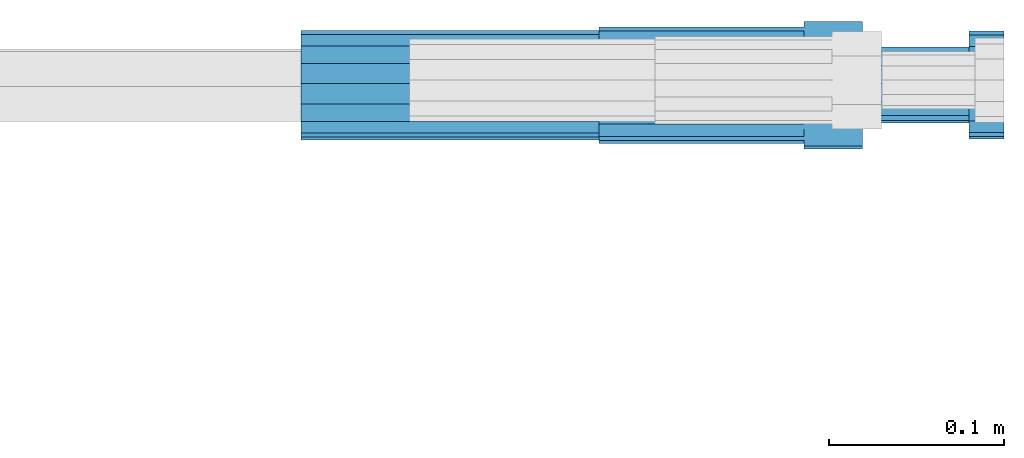
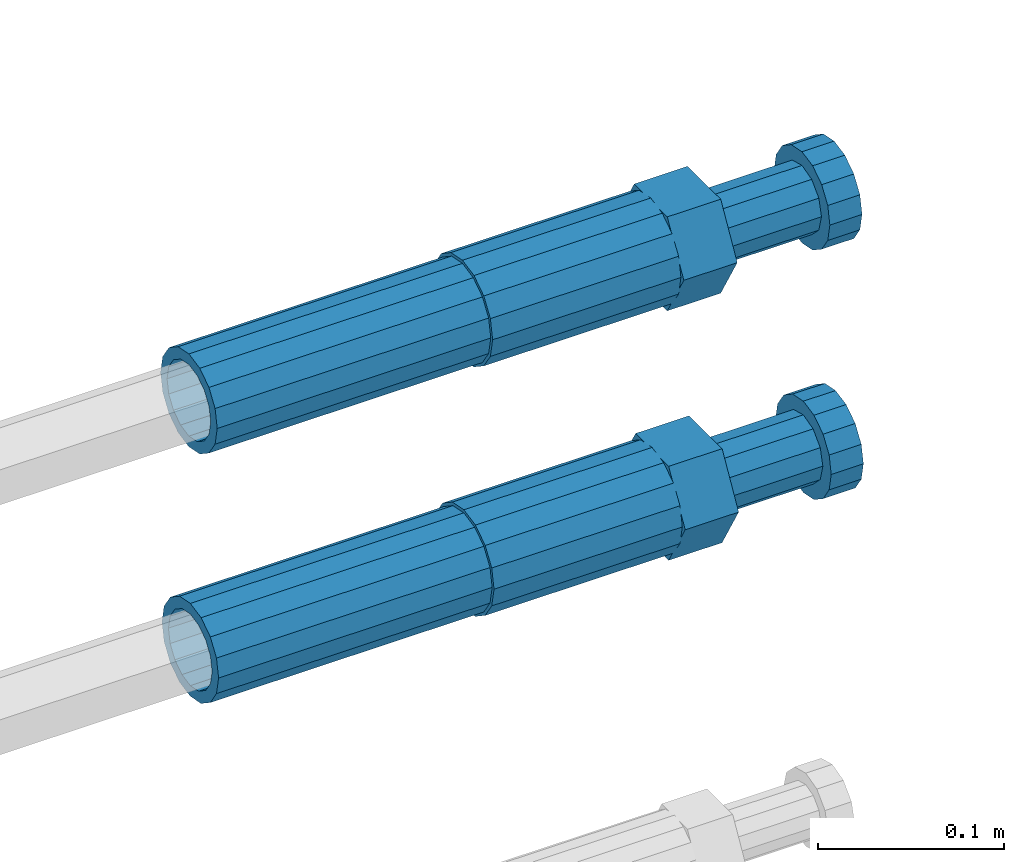
# One storey, part 111 of 119: 4 beams.
"""IFC2X3 building model written with IfcOpenShell, lengths in millimetres."""

from ifc_helpers import new_model, si_unit, frame, origin_with_axes, place, context, subcontext, project, spatial, faceted_brep, material, type_object, element, save


model = new_model("IFC2X3")

# Units and contexts
model_context = context("Model", 3, precision=1e-05, world=origin_with_axes())
body_context = subcontext(model_context, "Body", "Model", "MODEL_VIEW")
ifc_project = project(units=[si_unit("LENGTHUNIT", "METRE", prefix="MILLI"), si_unit("AREAUNIT", "SQUARE_METRE"), si_unit("VOLUMEUNIT", "CUBIC_METRE"), si_unit("MASSUNIT", "GRAM", prefix="KILO"), si_unit("TIMEUNIT", "SECOND"), si_unit("PLANEANGLEUNIT", "RADIAN"), si_unit("SOLIDANGLEUNIT", "STERADIAN"), si_unit("THERMODYNAMICTEMPERATUREUNIT", "DEGREE_CELSIUS"), si_unit("LUMINOUSINTENSITYUNIT", "LUMEN")], contexts=[model_context])

# Site, building, storey
site_placement = place(None, origin_with_axes())
site = spatial("IfcSite", under=ifc_project, at=site_placement, CompositionType="ELEMENT")
building_placement = place(site_placement, origin_with_axes())
building = spatial("IfcBuilding", under=site, at=building_placement, Name="Undefined", CompositionType="ELEMENT")
storey_placement = place(building_placement, origin_with_axes())
storey = spatial("IfcBuildingStorey", under=building, at=storey_placement, Name="Undefined", CompositionType="ELEMENT", Elevation=0.0)

# Beams
ifc_material = material(Name="STEEL/S275")
beam_type_1 = type_object("IfcBeamType", PredefinedType="NOTDEFINED")
beam_1_placement = place(storey_placement, frame((2039349.04023304, 6206399.98994599, 19251.9794145845), z_axis=(0.0, 0.0, 1.0), x_axis=(1.0, 0.0, 0.0)))
element("IfcBeam", 1, at=beam_1_placement, inside=storey, type_object=beam_type_1, material=ifc_material, Name="AG40N", context=body_context, shape_type="Brep", body=[
    faceted_brep([(1.62981450557709e-09, -23.4999999990687, 0.0), (7.45058059692383e-09, -21.7111690142192, 8.99306066057534), (170.000002125278, -21.711168999318, 8.99306066022245), (170.000002127141, -23.4999999844003, -3.66071617463604e-10), (4.65661287307739e-09, -16.6170093587134, 16.6170093578889), (170.000002122484, -16.6170093440451, 16.6170093575288), (1.86264514923096e-09, -8.99306066217832, 21.7111690140277), (170.000002118759, -8.99306064750999, 21.7111690136603), (2.3283064365387e-10, 9.31322574615479e-10, 23.5), (170.000002114102, 1.28056854009628e-08, 23.4999999996485), (-6.51925802230835e-09, 8.99306065868586, 21.7111690140241), (170.00000211224, 8.99306067335419, 21.7111690136639), (-7.45058059692383e-09, 16.6170093561523, 16.6170093578853), (170.000002109446, 16.6170093708206, 16.6170093575324), (-9.31322574615479e-09, 21.711169013055, 8.99306066057534), (170.000002108514, 21.7111690277234, 8.99306066022245), (-1.16415321826935e-09, 23.5000000009313, 0.0), (170.000002108514, 23.5000000144355, -3.66071617463604e-10), (-8.38190317153931e-09, 21.7111690151505, -8.99306066059444), (170.000002110377, 21.7111690300517, -8.9930606609546), (-5.58793544769287e-09, 16.6170093598776, -16.6170093579008), (170.000002113171, 16.6170093745459, -16.6170093582609), (-9.31322574615479e-10, 8.99306066334248, -21.7111690140396), (170.000002115965, 8.99306067801081, -21.7111690143961), (2.3283064365387e-10, 9.31322574615479e-10, -23.5), (170.00000211969, 1.7927959561348e-08, -23.5000000003843), (5.58793544769287e-09, -8.99306065752171, -21.7111690140396), (170.000002123415, -8.99306064285338, -21.7111690143961), (8.38190317153931e-09, -16.6170093549881, -16.6170093579008), (170.000002125278, -16.6170093403198, -16.6170093582646), (9.31322574615479e-09, -21.7111690121237, -8.99306066059444), (170.000002127141, -21.7111689972226, -8.9930606609546), (1.11758708953857e-08, -30.4999999990687, -9.54969436861575e-12), (1.30385160446167e-08, -28.1783257392235, -11.6718446871514), (170.000002129003, -28.1783257243223, -11.6718446875116), (170.000002129935, -30.4999999841675, -3.66071617463604e-10), (1.02445483207703e-08, -21.5667568228673, -21.5667568262129), (170.000002128072, -21.566756808199, -21.5667568265694), (7.45058059692383e-09, -11.6718446831219, -28.1783257416196), (170.000002125278, -11.6718446684536, -28.1783257419834), (3.72529029846191e-09, 3.95812094211578e-09, -30.5000000000277), (170.00000211969, 1.83936208486557e-08, -30.5000000003879), (-9.31322574615479e-10, 11.6718446905725, -28.1783257416232), (170.000002115965, 11.6718447052408, -28.1783257419797), (-6.51925802230835e-09, 21.5667568286881, -21.5667568262093), (170.000002110377, 21.5667568433564, -21.5667568265694), (-9.31322574615479e-09, 28.178325742716, -11.6718446871478), (170.000002108514, 28.1783257573843, -11.6718446875079), (-1.21071934700012e-08, 30.5, -5.91171556152403e-12), (170.000002106652, 30.5000000144355, -3.62433638656512e-10), (-1.21071934700012e-08, 28.1783257401548, 11.6718446871359), (170.00000210572, 28.1783257548232, 11.6718446867794), (-1.02445483207703e-08, 21.5667568240315, 21.5667568261974), (170.000002107583, 21.566756838467, 21.5667568258409), (-7.45058059692383e-09, 11.671844684286, 28.1783257416041), (170.000002110377, 11.6718446989544, 28.178325741244), (-2.79396772384644e-09, -2.56113708019257e-09, 30.5000000000159), (170.000002114102, 1.18743628263474e-08, 30.4999999996558), (1.86264514923096e-09, -11.6718446896411, 28.1783257416114), (170.000002118759, -11.67184467474, 28.178325741244), (7.45058059692383e-09, -21.5667568275239, 21.5667568261974), (170.000002123415, -21.5667568126228, 21.5667568258373), (1.02445483207703e-08, -28.1783257415518, 11.6718446871359), (170.000002127141, -28.1783257271163, 11.6718446867794)], [[[0, 1, 2, 3]], [[1, 4, 5, 2]], [[4, 6, 7, 5]], [[6, 8, 9, 7]], [[8, 10, 11, 9]], [[10, 12, 13, 11]], [[12, 14, 15, 13]], [[14, 16, 17, 15]], [[16, 18, 19, 17]], [[18, 20, 21, 19]], [[20, 22, 23, 21]], [[22, 24, 25, 23]], [[24, 26, 27, 25]], [[26, 28, 29, 27]], [[28, 30, 31, 29]], [[30, 0, 3, 31]], [[32, 33, 34, 35]], [[33, 36, 37, 34]], [[36, 38, 39, 37]], [[38, 40, 41, 39]], [[40, 42, 43, 41]], [[42, 44, 45, 43]], [[44, 46, 47, 45]], [[46, 48, 49, 47]], [[48, 50, 51, 49]], [[50, 52, 53, 51]], [[52, 54, 55, 53]], [[54, 56, 57, 55]], [[56, 58, 59, 57]], [[58, 60, 61, 59]], [[60, 62, 63, 61]], [[62, 32, 35, 63]], [[37, 39, 41, 43, 45, 47, 49, 51, 53, 55, 57, 59, 61, 63, 35, 34], [5, 7, 9, 11, 13, 15, 17, 19, 21, 23, 25, 27, 29, 31, 3, 2]], [[62, 60, 58, 56, 54, 52, 50, 48, 46, 44, 42, 40, 38, 36, 33, 32], [30, 28, 26, 24, 22, 20, 18, 16, 14, 12, 10, 8, 6, 4, 1, 0]]]),
])
beam_2_placement = place(storey_placement, frame((2039349.04023304, 6206401.47994599, 19414.989415702), z_axis=(0.0, 0.0, 1.0), x_axis=(1.0, 0.0, 0.0)))
element("IfcBeam", 2, at=beam_2_placement, inside=storey, type_object=beam_type_1, material=ifc_material, Name="AG40N", context=body_context, shape_type="Brep", body=[
    faceted_brep([(1.62981450557709e-09, -23.4999999990687, 0.0), (7.45058059692383e-09, -21.7111690142192, 8.99306066057534), (170.000002125278, -21.711168999318, 8.99306066022245), (170.000002127141, -23.4999999844003, -3.66071617463604e-10), (4.65661287307739e-09, -16.6170093587134, 16.6170093578889), (170.000002122484, -16.6170093440451, 16.6170093575288), (1.86264514923096e-09, -8.99306066217832, 21.7111690140277), (170.000002118759, -8.99306064750999, 21.7111690136603), (2.3283064365387e-10, 9.31322574615479e-10, 23.5), (170.000002114102, 1.28056854009628e-08, 23.4999999996485), (-6.51925802230835e-09, 8.99306065868586, 21.7111690140241), (170.00000211224, 8.99306067335419, 21.7111690136639), (-7.45058059692383e-09, 16.6170093561523, 16.6170093578853), (170.000002109446, 16.6170093708206, 16.6170093575324), (-9.31322574615479e-09, 21.711169013055, 8.99306066057534), (170.000002108514, 21.7111690277234, 8.99306066022245), (-1.16415321826935e-09, 23.5000000009313, 0.0), (170.000002108514, 23.5000000144355, -3.66071617463604e-10), (-8.38190317153931e-09, 21.7111690151505, -8.99306066059444), (170.000002110377, 21.7111690300517, -8.9930606609546), (-5.58793544769287e-09, 16.6170093598776, -16.6170093579008), (170.000002113171, 16.6170093745459, -16.6170093582609), (-9.31322574615479e-10, 8.99306066334248, -21.7111690140396), (170.000002115965, 8.99306067801081, -21.7111690143961), (2.3283064365387e-10, 9.31322574615479e-10, -23.5), (170.00000211969, 1.7927959561348e-08, -23.5000000003843), (5.58793544769287e-09, -8.99306065752171, -21.7111690140396), (170.000002123415, -8.99306064285338, -21.7111690143961), (8.38190317153931e-09, -16.6170093549881, -16.6170093579008), (170.000002125278, -16.6170093403198, -16.6170093582646), (9.31322574615479e-09, -21.7111690121237, -8.99306066059444), (170.000002127141, -21.7111689972226, -8.9930606609546), (1.11758708953857e-08, -30.4999999990687, -9.54969436861575e-12), (1.30385160446167e-08, -28.1783257392235, -11.6718446871514), (170.000002129003, -28.1783257243223, -11.6718446875116), (170.000002129935, -30.4999999841675, -3.66071617463604e-10), (1.02445483207703e-08, -21.5667568228673, -21.5667568262129), (170.000002128072, -21.566756808199, -21.5667568265694), (7.45058059692383e-09, -11.6718446831219, -28.1783257416196), (170.000002125278, -11.6718446684536, -28.1783257419834), (3.72529029846191e-09, 3.95812094211578e-09, -30.5000000000277), (170.00000211969, 1.83936208486557e-08, -30.5000000003879), (-9.31322574615479e-10, 11.6718446905725, -28.1783257416232), (170.000002115965, 11.6718447052408, -28.1783257419797), (-6.51925802230835e-09, 21.5667568286881, -21.5667568262093), (170.000002110377, 21.5667568433564, -21.5667568265694), (-9.31322574615479e-09, 28.178325742716, -11.6718446871478), (170.000002108514, 28.1783257573843, -11.6718446875079), (-1.21071934700012e-08, 30.5, -5.91171556152403e-12), (170.000002106652, 30.5000000144355, -3.62433638656512e-10), (-1.21071934700012e-08, 28.1783257401548, 11.6718446871359), (170.00000210572, 28.1783257548232, 11.6718446867794), (-1.02445483207703e-08, 21.5667568240315, 21.5667568261974), (170.000002107583, 21.566756838467, 21.5667568258409), (-7.45058059692383e-09, 11.671844684286, 28.1783257416041), (170.000002110377, 11.6718446989544, 28.178325741244), (-2.79396772384644e-09, -2.56113708019257e-09, 30.5000000000159), (170.000002114102, 1.18743628263474e-08, 30.4999999996558), (1.86264514923096e-09, -11.6718446896411, 28.1783257416114), (170.000002118759, -11.67184467474, 28.178325741244), (7.45058059692383e-09, -21.5667568275239, 21.5667568261974), (170.000002123415, -21.5667568126228, 21.5667568258373), (1.02445483207703e-08, -28.1783257415518, 11.6718446871359), (170.000002127141, -28.1783257271163, 11.6718446867794)], [[[0, 1, 2, 3]], [[1, 4, 5, 2]], [[4, 6, 7, 5]], [[6, 8, 9, 7]], [[8, 10, 11, 9]], [[10, 12, 13, 11]], [[12, 14, 15, 13]], [[14, 16, 17, 15]], [[16, 18, 19, 17]], [[18, 20, 21, 19]], [[20, 22, 23, 21]], [[22, 24, 25, 23]], [[24, 26, 27, 25]], [[26, 28, 29, 27]], [[28, 30, 31, 29]], [[30, 0, 3, 31]], [[32, 33, 34, 35]], [[33, 36, 37, 34]], [[36, 38, 39, 37]], [[38, 40, 41, 39]], [[40, 42, 43, 41]], [[42, 44, 45, 43]], [[44, 46, 47, 45]], [[46, 48, 49, 47]], [[48, 50, 51, 49]], [[50, 52, 53, 51]], [[52, 54, 55, 53]], [[54, 56, 57, 55]], [[56, 58, 59, 57]], [[58, 60, 61, 59]], [[60, 62, 63, 61]], [[62, 32, 35, 63]], [[37, 39, 41, 43, 45, 47, 49, 51, 53, 55, 57, 59, 61, 63, 35, 34], [5, 7, 9, 11, 13, 15, 17, 19, 21, 23, 25, 27, 29, 31, 3, 2]], [[62, 60, 58, 56, 54, 52, 50, 48, 46, 44, 42, 40, 38, 36, 33, 32], [30, 28, 26, 24, 22, 20, 18, 16, 14, 12, 10, 8, 6, 4, 1, 0]]]),
])
beam_type_2 = type_object("IfcBeamType", Name="ROD65", PredefinedType="NOTDEFINED")
beam_3_placement = place(storey_placement, frame((2039519.04023304, 6206399.98994599, 19251.9794170917), z_axis=(0.0, 0.0, 1.0), x_axis=(1.0, 0.0, 0.0)))
element("IfcBeam", 3, at=beam_3_placement, inside=storey, type_object=beam_type_2, material=ifc_material, Name="AGB40", ObjectType="ROD65", context=body_context, shape_type="Brep", body=[
    faceted_brep([(116.999999999069, 17.8249999252148, 30.8738056446964), (116.999999998137, 22.0056957420893, 23.632628078838), (116.999999999069, 12.4372115600854, 30.0260848066173), (116.999999999069, 8.17543111252598, 30.8738056446964), (117.000000000931, -17.8250000746921, 30.8738056446964), (150.200000001118, -17.8250000723638, 30.8738056446964), (150.199999999255, 17.8249999275431, 30.8738056446964), (117.000000000931, -8.17543109622784, 30.8738056446964), (117.000000001863, -22.0056959956419, 23.6326278985034), (117.000000000931, -12.4372115437873, 30.0260848066173), (117.000000001863, -35.6500000746455, -2.18278728425503e-10), (150.200000002049, -35.6500000723172, -2.18278728425503e-10), (117.000000001863, -30.8443149488885, 8.32369080289209), (117.000000001863, -30.8443149488885, -8.32369080355784), (117.000000002794, -32.4999999918509, 0.0), (117.000000000931, -17.8250000746921, -30.873805645133), (150.200000001118, -17.8250000723638, -30.873805645133), (117.000000001863, -22.0056959961075, -23.6326278982269), (117.000000000931, -8.17543109389953, -30.873805645133), (117.000000000931, -12.4372115437873, -30.0260848066173), (116.999999999069, 17.8249999252148, -30.873805645133), (150.199999999255, 17.8249999275431, -30.873805645133), (116.999999999069, 8.17543111019768, -30.873805645133), (116.999999999069, 12.4372115600854, -30.0260848066173), (116.999999998137, 22.005695742555, -23.6326280785652), (116.999999998137, 35.6499999251682, -2.18278728425503e-10), (150.199999998324, 35.6499999277294, -2.18278728425503e-10), (116.999999998137, 30.8443150522653, -8.32369036550881), (116.999999997206, 32.5000000081491, 0.0), (116.999999998137, 30.8443150522653, 8.32369036483942), (1.86264514923096e-09, -22.9809703885112, 22.9809703885621), (1.86264514923096e-09, -30.0260848065373, 12.4372115518672), (117.000000001863, -30.0260847983882, 12.4372115518672), (117.000000001863, -22.9809703803621, 22.9809703885621), (-1.86264514923096e-09, 22.9809703885112, -22.9809703885621), (-1.86264514923096e-09, 30.0260848065373, -12.4372115518672), (116.999999998137, 30.0260848146863, -12.4372115518672), (116.999999998137, 22.9809703966603, -22.9809703885621), (1.86264514923096e-09, -30.0260848065373, -12.4372115518672), (1.86264514923096e-09, -22.9809703885112, -22.9809703885621), (117.000000001863, -22.9809703803621, -22.9809703885621), (117.000000001863, -30.0260847983882, -12.4372115518672), (9.31322574615479e-10, -12.4372115519363, 30.0260848066173), (0.0, 0.0, 32.5), (-9.31322574615479e-10, 12.4372115519363, 30.0260848066173), (-1.86264514923096e-09, 22.9809703885112, 22.9809703885621), (-1.86264514923096e-09, 30.0260848065373, 12.4372115518672), (-2.79396772384644e-09, 32.5, 0.0), (-9.31322574615479e-10, 12.4372115519363, -30.0260848066173), (0.0, 0.0, -32.5), (9.31322574615479e-10, -12.4372115519363, -30.0260848066173), (2.79396772384644e-09, -32.5, 0.0), (116.999999998137, 22.9809703966603, 22.9809703885621), (116.999999998137, 30.0260848146863, 12.4372115518672), (117.0, 8.14907252788544e-09, -32.5), (117.0, 8.14907252788544e-09, 32.5), (150.200000000186, -10.5000000959262, 18.1865334791873), (150.199999999255, -9.59262251853943e-08, 20.9999999997126), (150.199999998324, 10.4999999040738, 18.1865334791873), (150.199999997392, 18.1865333835594, 10.4999999997126), (150.199999997392, 20.9999999040738, -2.87400325760245e-10), (150.199999997392, 18.1865333835594, -10.5000000002874), (150.199999998324, 10.4999999040738, -18.1865334797621), (150.199999999255, -9.59262251853943e-08, -21.0000000002874), (150.200000000186, -10.5000000959262, -18.1865334797621), (150.200000000186, -18.1865335754119, -10.5000000002874), (150.200000001118, -21.0000000959262, -2.87400325760245e-10), (150.200000000186, -18.1865335754119, 10.4999999997126), (210.979999999516, 10.4999999082647, 18.1865334791873), (210.979999999516, -9.17352735996246e-08, 20.9999999997126), (210.979999997653, 18.1865333877504, 10.4999999997126), (210.979999997653, 20.9999999082647, -2.87400325760245e-10), (210.979999997653, 18.1865333877504, -10.5000000002874), (210.979999999516, 10.4999999082647, -18.1865334797621), (210.979999999516, -9.17352735996246e-08, -21.0000000002874), (210.979999999516, -10.5000000917353, -18.1865334797621), (210.980000000447, -18.1865335712209, -10.5000000002874), (210.980000001378, -21.0000000917353, -2.87400325760245e-10), (210.980000000447, -18.1865335712209, 10.4999999997126), (210.979999999516, -10.5000000917353, 18.1865334791873), (211.001368402503, -27.7269939335529, -11.4911163272045), (211.003082515672, -21.2238095656503, -21.2238154190527), (231.002518340945, -21.2131946226582, -21.2132004554769), (231.000804228708, -27.7163789905608, -11.4805013636287), (211.001368415542, -11.4911086384673, -27.7269970399575), (231.000804241747, -11.4804936954752, -27.7163820763781), (210.996487061493, -0.0106066407170147, -30.0106107396168), (230.995922887698, 8.30227509140968e-06, -29.999995776041), (210.98918159306, 11.4698940692469, -27.7269970332745), (230.988617419265, 11.4805090120062, -27.7163820696951), (210.980564201251, 21.2025913291145, -21.2238154067054), (230.980000027455, 21.2132062721066, -21.2132004431296), (210.971946807578, 27.7057702087332, -11.4911163110701), (230.971382633783, 27.7163851517253, -11.4805013474943), (210.964641331695, 29.9893806746695, -0.0106149565435771), (230.9640771579, 29.9999956176616, 7.03221303410828e-09), (210.959759964608, 27.7057637346443, 11.4698863966551), (230.959195790812, 27.7163786776364, 11.4805013602345), (210.958045851439, 21.2025793667417, 21.2025854885032), (230.957481677644, 21.2131943097338, 21.2132004520827), (210.959759951569, 11.4698784395587, 27.705767109408), (230.959195776843, 11.4804933823179, 27.7163820729838), (210.964641305618, -0.0106235581915826, 29.9893808090674), (230.964077131823, -8.61519947648048e-06, 29.9999957726432), (210.971946774051, -11.4911242681555, 27.7057671027251), (230.971382599324, -11.4805093251634, 27.7163820663009), (210.98056416586, -21.2238215280231, 21.2025854761559), (230.979999991134, -21.2132065852638, 21.2132004397354), (210.989181559533, -27.7270004076418, 11.4698863805206), (230.988617384806, -27.7163854646496, 11.4805013441), (210.996487035416, -30.0106108735781, -0.0106149740058754), (230.995922861621, -29.999995930586, -1.04300852399319e-08)], [[[0, 1, 2, 3]], [[4, 5, 6, 0, 3, 7]], [[8, 4, 7, 9]], [[10, 11, 5, 4, 8, 12]], [[13, 10, 12, 14]], [[15, 16, 11, 10, 13, 17]], [[18, 15, 17, 19]], [[20, 21, 16, 15, 18, 22]], [[20, 22, 23, 24]], [[25, 26, 21, 20, 24, 27]], [[25, 27, 28, 29]], [[30, 31, 32, 33]], [[34, 35, 36, 37]], [[38, 39, 40, 41]], [[31, 30, 42, 43, 44, 45, 46, 47, 35, 34, 48, 49, 50, 39, 38, 51]], [[46, 45, 52, 53]], [[28, 47, 46, 53, 29]], [[27, 36, 35, 47, 28]], [[24, 37, 36, 27]], [[23, 48, 34, 37, 24]], [[22, 54, 49, 48, 23]], [[18, 54, 22]], [[19, 50, 49, 54, 18]], [[17, 40, 39, 50, 19]], [[13, 41, 40, 17]], [[14, 51, 38, 41, 13]], [[12, 32, 31, 51, 14]], [[8, 33, 32, 12]], [[9, 42, 30, 33, 8]], [[7, 55, 43, 42, 9]], [[3, 55, 7]], [[2, 44, 43, 55, 3]], [[1, 52, 45, 44, 2]], [[29, 53, 52, 1]], [[0, 6, 26, 25, 29, 1]], [[5, 11, 16, 21, 26, 6], [56, 57, 58, 59, 60, 61, 62, 63, 64, 65, 66, 67]], [[68, 58, 57, 69]], [[70, 59, 58, 68]], [[71, 60, 59, 70]], [[72, 61, 60, 71]], [[73, 62, 61, 72]], [[74, 63, 62, 73]], [[75, 64, 63, 74]], [[76, 65, 64, 75]], [[77, 66, 65, 76]], [[78, 67, 66, 77]], [[79, 56, 67, 78]], [[69, 57, 56, 79]], [[80, 81, 82, 83]], [[81, 84, 85, 82]], [[84, 86, 87, 85]], [[86, 88, 89, 87]], [[88, 90, 91, 89]], [[90, 92, 93, 91]], [[92, 94, 95, 93]], [[94, 96, 97, 95]], [[96, 98, 99, 97]], [[98, 100, 101, 99]], [[100, 102, 103, 101]], [[102, 104, 105, 103]], [[104, 106, 107, 105]], [[106, 108, 109, 107]], [[108, 110, 111, 109]], [[82, 85, 87, 89, 91, 93, 95, 97, 99, 101, 103, 105, 107, 109, 111, 83]], [[110, 80, 83, 111]], [[108, 106, 104, 102, 100, 98, 96, 94, 92, 90, 88, 86, 84, 81, 80, 110], [78, 77, 76, 75, 74, 73, 72, 71, 70, 68, 69, 79]]]),
])
beam_4_placement = place(storey_placement, frame((2039519.04023304, 6206401.47994599, 19414.989418229), z_axis=(0.0, 0.0, 1.0), x_axis=(1.0, 0.0, 0.0)))
element("IfcBeam", 4, at=beam_4_placement, inside=storey, type_object=beam_type_2, material=ifc_material, Name="AGB40", ObjectType="ROD65", context=body_context, shape_type="Brep", body=[
    faceted_brep([(116.999999999069, 17.8249999252148, 30.8738056446964), (116.999999998137, 22.0056957420893, 23.632628078838), (116.999999999069, 12.4372115600854, 30.0260848066173), (116.999999999069, 8.17543111252598, 30.8738056446964), (117.000000000931, -17.8250000746921, 30.8738056446964), (150.200000001118, -17.8250000723638, 30.8738056446964), (150.199999999255, 17.8249999275431, 30.8738056446964), (117.000000000931, -8.17543109622784, 30.8738056446964), (117.000000001863, -22.0056959956419, 23.6326278985034), (117.000000000931, -12.4372115437873, 30.0260848066173), (117.000000001863, -35.6500000746455, -2.18278728425503e-10), (150.200000002049, -35.6500000723172, -2.18278728425503e-10), (117.000000001863, -30.8443149488885, 8.32369080289209), (117.000000001863, -30.8443149488885, -8.32369080355784), (117.000000002794, -32.4999999918509, 0.0), (117.000000000931, -17.8250000746921, -30.873805645133), (150.200000001118, -17.8250000723638, -30.873805645133), (117.000000001863, -22.0056959961075, -23.6326278982269), (117.000000000931, -8.17543109389953, -30.873805645133), (117.000000000931, -12.4372115437873, -30.0260848066173), (116.999999999069, 17.8249999252148, -30.873805645133), (150.199999999255, 17.8249999275431, -30.873805645133), (116.999999999069, 8.17543111019768, -30.873805645133), (116.999999999069, 12.4372115600854, -30.0260848066173), (116.999999998137, 22.005695742555, -23.6326280785652), (116.999999998137, 35.6499999251682, -2.18278728425503e-10), (150.199999998324, 35.6499999277294, -2.18278728425503e-10), (116.999999998137, 30.8443150522653, -8.32369036550881), (116.999999997206, 32.5000000081491, 0.0), (116.999999998137, 30.8443150522653, 8.32369036483942), (1.86264514923096e-09, -22.9809703885112, 22.9809703885621), (1.86264514923096e-09, -30.0260848065373, 12.4372115518672), (117.000000001863, -30.0260847983882, 12.4372115518672), (117.000000001863, -22.9809703803621, 22.9809703885621), (-1.86264514923096e-09, 22.9809703885112, -22.9809703885621), (-1.86264514923096e-09, 30.0260848065373, -12.4372115518672), (116.999999998137, 30.0260848146863, -12.4372115518672), (116.999999998137, 22.9809703966603, -22.9809703885621), (1.86264514923096e-09, -30.0260848065373, -12.4372115518672), (1.86264514923096e-09, -22.9809703885112, -22.9809703885621), (117.000000001863, -22.9809703803621, -22.9809703885621), (117.000000001863, -30.0260847983882, -12.4372115518672), (9.31322574615479e-10, -12.4372115519363, 30.0260848066173), (0.0, 0.0, 32.5), (-9.31322574615479e-10, 12.4372115519363, 30.0260848066173), (-1.86264514923096e-09, 22.9809703885112, 22.9809703885621), (-1.86264514923096e-09, 30.0260848065373, 12.4372115518672), (-2.79396772384644e-09, 32.5, 0.0), (-9.31322574615479e-10, 12.4372115519363, -30.0260848066173), (0.0, 0.0, -32.5), (9.31322574615479e-10, -12.4372115519363, -30.0260848066173), (2.79396772384644e-09, -32.5, 0.0), (116.999999998137, 22.9809703966603, 22.9809703885621), (116.999999998137, 30.0260848146863, 12.4372115518672), (117.0, 8.14907252788544e-09, -32.5), (117.0, 8.14907252788544e-09, 32.5), (150.200000000186, -10.5000000959262, 18.1865334791873), (150.199999999255, -9.59262251853943e-08, 20.9999999997126), (150.199999998324, 10.4999999040738, 18.1865334791873), (150.199999997392, 18.1865333835594, 10.4999999997126), (150.199999997392, 20.9999999040738, -2.87400325760245e-10), (150.199999997392, 18.1865333835594, -10.5000000002874), (150.199999998324, 10.4999999040738, -18.1865334797621), (150.199999999255, -9.59262251853943e-08, -21.0000000002874), (150.200000000186, -10.5000000959262, -18.1865334797621), (150.200000000186, -18.1865335754119, -10.5000000002874), (150.200000001118, -21.0000000959262, -2.87400325760245e-10), (150.200000000186, -18.1865335754119, 10.4999999997126), (210.979999999516, 10.4999999082647, 18.1865334791873), (210.979999999516, -9.17352735996246e-08, 20.9999999997126), (210.979999997653, 18.1865333877504, 10.4999999997126), (210.979999997653, 20.9999999082647, -2.87400325760245e-10), (210.979999997653, 18.1865333877504, -10.5000000002874), (210.979999999516, 10.4999999082647, -18.1865334797621), (210.979999999516, -9.17352735996246e-08, -21.0000000002874), (210.979999999516, -10.5000000917353, -18.1865334797621), (210.980000000447, -18.1865335712209, -10.5000000002874), (210.980000001378, -21.0000000917353, -2.87400325760245e-10), (210.980000000447, -18.1865335712209, 10.4999999997126), (210.979999999516, -10.5000000917353, 18.1865334791873), (211.001368402503, -27.7269939335529, -11.4911163272045), (211.003082515672, -21.2238095656503, -21.2238154190527), (231.002518340945, -21.2131946226582, -21.2132004554769), (231.000804228708, -27.7163789905608, -11.4805013636287), (211.001368415542, -11.4911086384673, -27.7269970399575), (231.000804241747, -11.4804936954752, -27.7163820763781), (210.996487061493, -0.0106066407170147, -30.0106107396168), (230.995922887698, 8.30227509140968e-06, -29.999995776041), (210.98918159306, 11.4698940692469, -27.7269970332745), (230.988617419265, 11.4805090120062, -27.7163820696951), (210.980564201251, 21.2025913291145, -21.2238154067054), (230.980000027455, 21.2132062721066, -21.2132004431296), (210.971946807578, 27.7057702087332, -11.4911163110701), (230.971382633783, 27.7163851517253, -11.4805013474943), (210.964641331695, 29.9893806746695, -0.0106149565435771), (230.9640771579, 29.9999956176616, 7.03221303410828e-09), (210.959759964608, 27.7057637346443, 11.4698863966551), (230.959195790812, 27.7163786776364, 11.4805013602345), (210.958045851439, 21.2025793667417, 21.2025854885032), (230.957481677644, 21.2131943097338, 21.2132004520827), (210.959759951569, 11.4698784395587, 27.705767109408), (230.959195776843, 11.4804933823179, 27.7163820729838), (210.964641305618, -0.0106235581915826, 29.9893808090674), (230.964077131823, -8.61519947648048e-06, 29.9999957726432), (210.971946774051, -11.4911242681555, 27.7057671027251), (230.971382599324, -11.4805093251634, 27.7163820663009), (210.98056416586, -21.2238215280231, 21.2025854761559), (230.979999991134, -21.2132065852638, 21.2132004397354), (210.989181559533, -27.7270004076418, 11.4698863805206), (230.988617384806, -27.7163854646496, 11.4805013441), (210.996487035416, -30.0106108735781, -0.0106149740058754), (230.995922861621, -29.999995930586, -1.04300852399319e-08)], [[[0, 1, 2, 3]], [[4, 5, 6, 0, 3, 7]], [[8, 4, 7, 9]], [[10, 11, 5, 4, 8, 12]], [[13, 10, 12, 14]], [[15, 16, 11, 10, 13, 17]], [[18, 15, 17, 19]], [[20, 21, 16, 15, 18, 22]], [[20, 22, 23, 24]], [[25, 26, 21, 20, 24, 27]], [[25, 27, 28, 29]], [[30, 31, 32, 33]], [[34, 35, 36, 37]], [[38, 39, 40, 41]], [[31, 30, 42, 43, 44, 45, 46, 47, 35, 34, 48, 49, 50, 39, 38, 51]], [[46, 45, 52, 53]], [[28, 47, 46, 53, 29]], [[27, 36, 35, 47, 28]], [[24, 37, 36, 27]], [[23, 48, 34, 37, 24]], [[22, 54, 49, 48, 23]], [[18, 54, 22]], [[19, 50, 49, 54, 18]], [[17, 40, 39, 50, 19]], [[13, 41, 40, 17]], [[14, 51, 38, 41, 13]], [[12, 32, 31, 51, 14]], [[8, 33, 32, 12]], [[9, 42, 30, 33, 8]], [[7, 55, 43, 42, 9]], [[3, 55, 7]], [[2, 44, 43, 55, 3]], [[1, 52, 45, 44, 2]], [[29, 53, 52, 1]], [[0, 6, 26, 25, 29, 1]], [[5, 11, 16, 21, 26, 6], [56, 57, 58, 59, 60, 61, 62, 63, 64, 65, 66, 67]], [[68, 58, 57, 69]], [[70, 59, 58, 68]], [[71, 60, 59, 70]], [[72, 61, 60, 71]], [[73, 62, 61, 72]], [[74, 63, 62, 73]], [[75, 64, 63, 74]], [[76, 65, 64, 75]], [[77, 66, 65, 76]], [[78, 67, 66, 77]], [[79, 56, 67, 78]], [[69, 57, 56, 79]], [[80, 81, 82, 83]], [[81, 84, 85, 82]], [[84, 86, 87, 85]], [[86, 88, 89, 87]], [[88, 90, 91, 89]], [[90, 92, 93, 91]], [[92, 94, 95, 93]], [[94, 96, 97, 95]], [[96, 98, 99, 97]], [[98, 100, 101, 99]], [[100, 102, 103, 101]], [[102, 104, 105, 103]], [[104, 106, 107, 105]], [[106, 108, 109, 107]], [[108, 110, 111, 109]], [[82, 85, 87, 89, 91, 93, 95, 97, 99, 101, 103, 105, 107, 109, 111, 83]], [[110, 80, 83, 111]], [[108, 106, 104, 102, 100, 98, 96, 94, 92, 90, 88, 86, 84, 81, 80, 110], [78, 77, 76, 75, 74, 73, 72, 71, 70, 68, 69, 79]]]),
])

save(model, "model.ifc")
